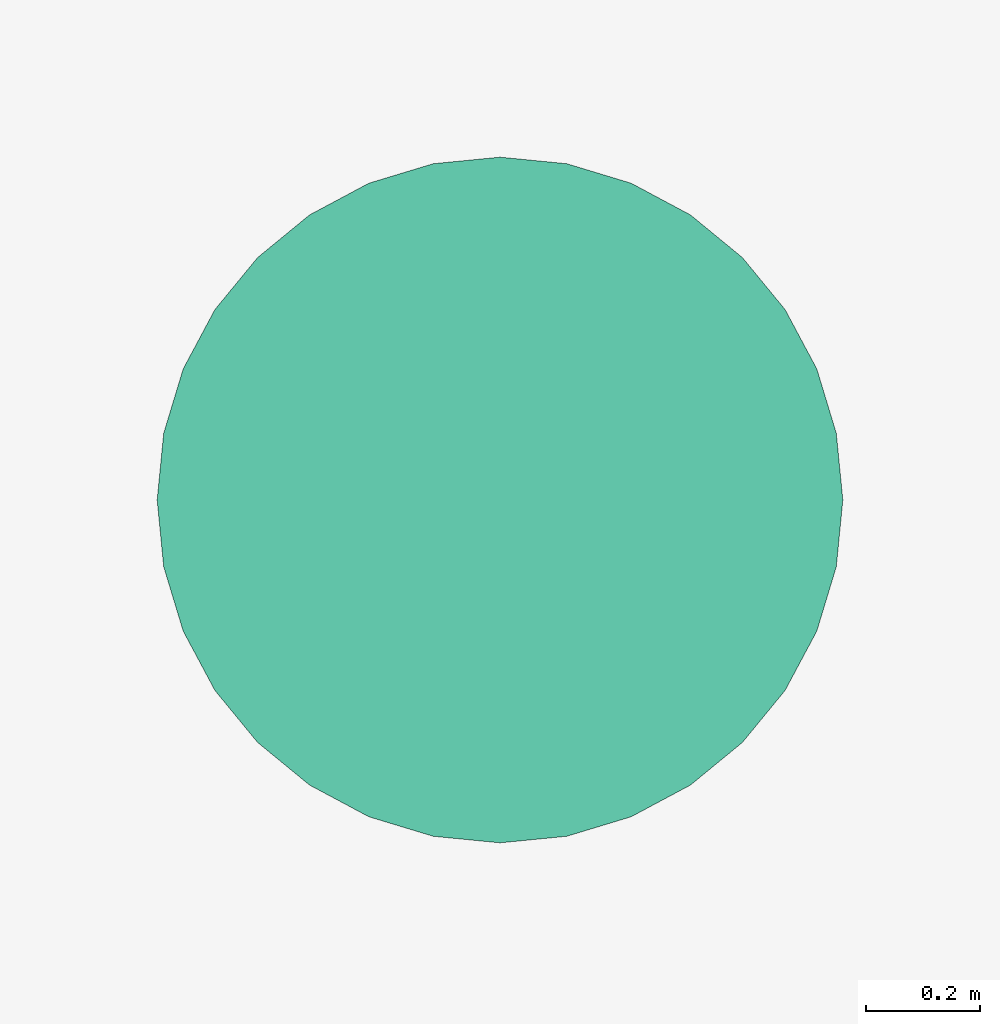
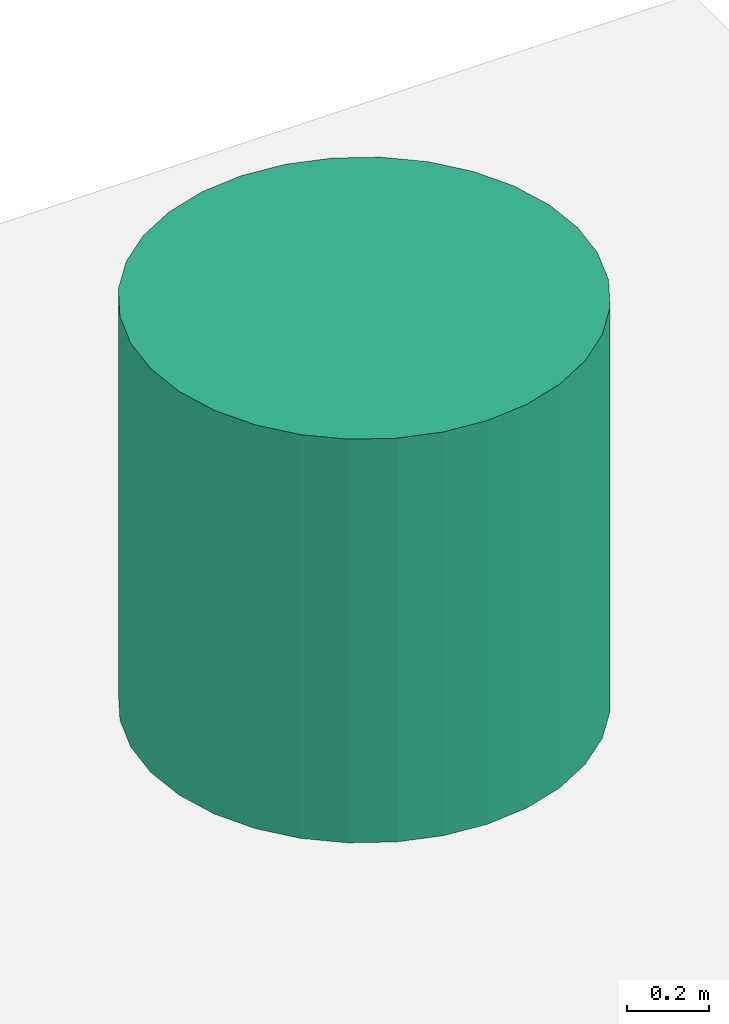
# One storey, part 2 of 2: 1 tank.
"""IFC4X3_ADD2 building model written with IfcOpenShell, lengths in metres."""

from ifc_helpers import new_model, entity, si_unit, converted_unit, frame, origin_with_axes, origin_2d_with_axis, place, context, subcontext, project, spatial, polygons, source, transform, mapped, type_object, type_shapes, element, save


model = new_model("IFC4X3_ADD2")

# Units and contexts
model_context = context("Model", 3, precision=1e-05, world=origin_with_axes())
plan_context = context("Plan", 2, precision=1e-05, world=origin_2d_with_axis())
body_context = subcontext(model_context, "Body", "Model", "MODEL_VIEW")
ifc_project = project(units=[si_unit("VOLUMEUNIT", "CUBIC_METRE"), si_unit("LENGTHUNIT", "METRE"), converted_unit("PLANEANGLEUNIT", "degree", entity("IfcReal", 0.0174532925199433), si_unit("PLANEANGLEUNIT", "RADIAN"), dimensions=[0, 0, 0, 0, 0, 0, 0]), si_unit("AREAUNIT", "SQUARE_METRE")], contexts=[model_context, plan_context])

# Site, building, storey
site_placement = place(None, origin_with_axes())
site = spatial("IfcSite", under=ifc_project, at=site_placement)
building_placement = place(site_placement, origin_with_axes())
building = spatial("IfcBuilding", under=site, at=building_placement, Name="Building")
storey_placement = place(building_placement, frame((0.0, 0.0, 5.69999980926514), z_axis=(0.0, 0.0, 1.0), x_axis=(1.0, 0.0, 0.0)))
storey = spatial("IfcBuildingStorey", under=building, at=storey_placement)

# Tank
tank_type = type_object("IfcTankType", Name="1000L Water Tank", PredefinedType="STORAGE")
shared_shape = source(origin_with_axes(), body_context, "Body", "Tessellation", [
    polygons([(0.0, 0.600000023841858, 0.0), (0.0, 0.600000023841858, 1.20000004768372), (0.11705420166254, 0.588471174240112, 0.0), (0.11705420166254, 0.588471174240112, 1.20000004768372), (0.229610085487366, 0.554327726364136, 0.0), (0.229610085487366, 0.554327726364136, 1.20000004768372), (0.333342164754868, 0.498881787061691, 0.0), (0.333342164754868, 0.498881787061691, 1.20000004768372), (0.424264073371887, 0.424264073371887, 0.0), (0.424264073371887, 0.424264073371887, 1.20000004768372), (0.498881787061691, 0.333342164754868, 0.0), (0.498881787061691, 0.333342164754868, 1.20000004768372), (0.554327726364136, 0.229610085487366, 0.0), (0.554327726364136, 0.229610085487366, 1.20000004768372), (0.588471174240112, 0.11705420166254, 0.0), (0.588471174240112, 0.11705420166254, 1.20000004768372), (0.600000023841858, 0.0, 0.0), (0.600000023841858, 0.0, 1.20000004768372), (0.588471174240112, -0.11705420166254, 0.0), (0.588471174240112, -0.11705420166254, 1.20000004768372), (0.554327726364136, -0.229610085487366, 0.0), (0.554327726364136, -0.229610085487366, 1.20000004768372), (0.498881787061691, -0.333342164754868, 0.0), (0.498881787061691, -0.333342164754868, 1.20000004768372), (0.424264073371887, -0.424264073371887, 0.0), (0.424264073371887, -0.424264073371887, 1.20000004768372), (0.333342164754868, -0.498881787061691, 0.0), (0.333342164754868, -0.498881787061691, 1.20000004768372), (0.229610085487366, -0.554327726364136, 0.0), (0.229610085487366, -0.554327726364136, 1.20000004768372), (0.11705420166254, -0.588471174240112, 0.0), (0.11705420166254, -0.588471174240112, 1.20000004768372), (0.0, -0.600000023841858, 0.0), (0.0, -0.600000023841858, 1.20000004768372), (-0.11705420166254, -0.588471174240112, 0.0), (-0.11705420166254, -0.588471174240112, 1.20000004768372), (-0.229610085487366, -0.554327726364136, 0.0), (-0.229610085487366, -0.554327726364136, 1.20000004768372), (-0.333342164754868, -0.498881787061691, 0.0), (-0.333342164754868, -0.498881787061691, 1.20000004768372), (-0.424264073371887, -0.424264073371887, 0.0), (-0.424264073371887, -0.424264073371887, 1.20000004768372), (-0.498881787061691, -0.333342164754868, 0.0), (-0.498881787061691, -0.333342164754868, 1.20000004768372), (-0.554327726364136, -0.229610085487366, 0.0), (-0.554327726364136, -0.229610085487366, 1.20000004768372), (-0.588471174240112, -0.11705420166254, 0.0), (-0.588471174240112, -0.11705420166254, 1.20000004768372), (-0.600000023841858, 0.0, 0.0), (-0.600000023841858, 0.0, 1.20000004768372), (-0.588471174240112, 0.11705420166254, 0.0), (-0.588471174240112, 0.11705420166254, 1.20000004768372), (-0.554327726364136, 0.229610085487366, 0.0), (-0.554327726364136, 0.229610085487366, 1.20000004768372), (-0.498881787061691, 0.333342164754868, 0.0), (-0.498881787061691, 0.333342164754868, 1.20000004768372), (-0.424264073371887, 0.424264073371887, 0.0), (-0.424264073371887, 0.424264073371887, 1.20000004768372), (-0.333342164754868, 0.498881787061691, 0.0), (-0.333342164754868, 0.498881787061691, 1.20000004768372), (-0.229610085487366, 0.554327726364136, 0.0), (-0.229610085487366, 0.554327726364136, 1.20000004768372), (-0.11705420166254, 0.588471174240112, 0.0), (-0.11705420166254, 0.588471174240112, 1.20000004768372)], [[[1, 2, 4, 3]], [[3, 4, 6, 5]], [[5, 6, 8, 7]], [[7, 8, 10, 9]], [[9, 10, 12, 11]], [[11, 12, 14, 13]], [[13, 14, 16, 15]], [[15, 16, 18, 17]], [[17, 18, 20, 19]], [[19, 20, 22, 21]], [[21, 22, 24, 23]], [[23, 24, 26, 25]], [[25, 26, 28, 27]], [[27, 28, 30, 29]], [[29, 30, 32, 31]], [[31, 32, 34, 33]], [[33, 34, 36, 35]], [[35, 36, 38, 37]], [[37, 38, 40, 39]], [[39, 40, 42, 41]], [[41, 42, 44, 43]], [[43, 44, 46, 45]], [[45, 46, 48, 47]], [[47, 48, 50, 49]], [[49, 50, 52, 51]], [[51, 52, 54, 53]], [[53, 54, 56, 55]], [[55, 56, 58, 57]], [[57, 58, 60, 59]], [[59, 60, 62, 61]], [[4, 2, 64, 62, 60, 58, 56, 54, 52, 50, 48, 46, 44, 42, 40, 38, 36, 34, 32, 30, 28, 26, 24, 22, 20, 18, 16, 14, 12, 10, 8, 6]], [[61, 62, 64, 63]], [[63, 64, 2, 1]], [[1, 3, 5, 7, 9, 11, 13, 15, 17, 19, 21, 23, 25, 27, 29, 31, 33, 35, 37, 39, 41, 43, 45, 47, 49, 51, 53, 55, 57, 59, 61, 63]]]),
])
type_shapes(tank_type, [shared_shape])
tank_placement = place(storey_placement, frame((22.6876373291016, 21.1401405334473, 0.387853145599362), z_axis=(0.0, 0.0, 1.0), x_axis=(1.0, 0.0, 0.0)))
element("IfcTank", 1, at=tank_placement, inside=storey, type_object=tank_type, Name="Tank", context=body_context, shape_type="MappedRepresentation", body=[
    mapped(shared_shape, transform((0.0, 0.0, 0.0), x_axis=(1.0, 0.0, 0.0), y_axis=(0.0, 1.0, 0.0), z_axis=(0.0, 0.0, 1.0), scale=1.0)),
])

save(model, "model.ifc")
